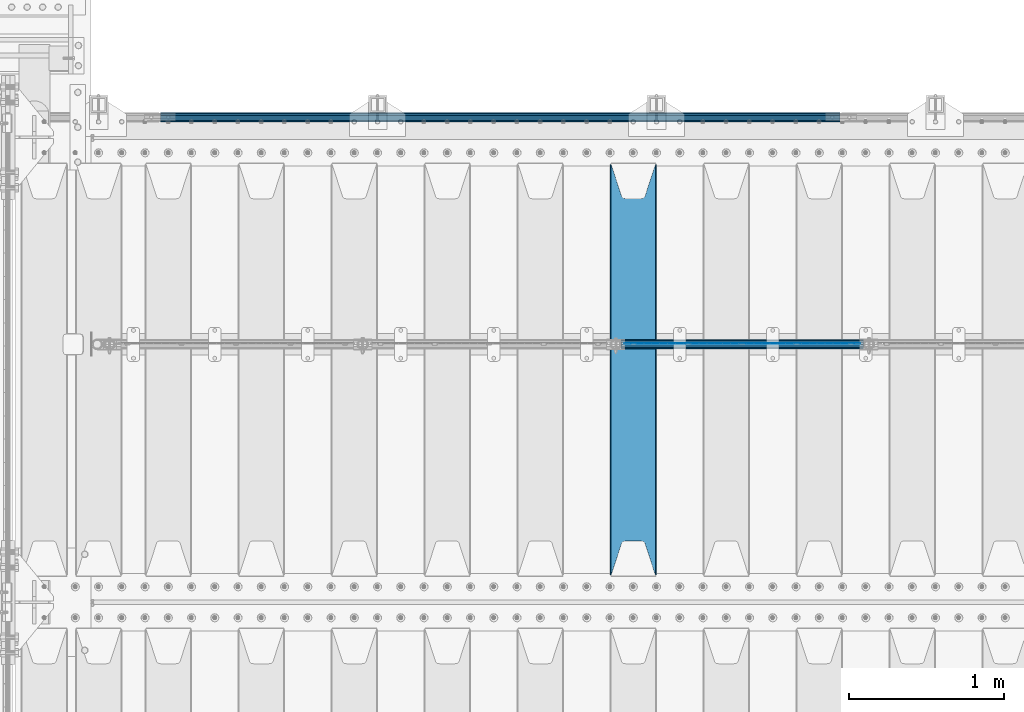
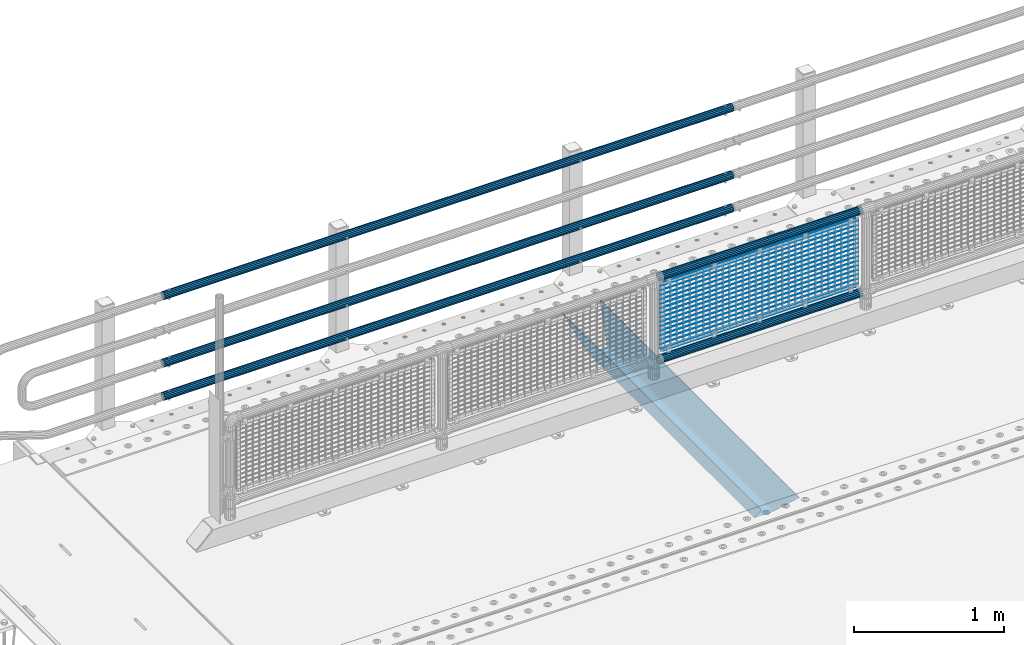
# One storey, part 130 of 270: 23 beams.
"""IFC2X3 building model written with IfcOpenShell, lengths in millimetres."""

from ifc_helpers import new_model, si_unit, frame, origin_with_axes, place, context, subcontext, project, spatial, faceted_brep, material, type_object, element, save


model = new_model("IFC2X3")

# Units and contexts
model_context = context("Model", 3, precision=1e-05, world=origin_with_axes())
body_context = subcontext(model_context, "Body", "Model", "MODEL_VIEW")
ifc_project = project(units=[si_unit("LENGTHUNIT", "METRE", prefix="MILLI"), si_unit("AREAUNIT", "SQUARE_METRE"), si_unit("VOLUMEUNIT", "CUBIC_METRE"), si_unit("MASSUNIT", "GRAM", prefix="KILO"), si_unit("TIMEUNIT", "SECOND"), si_unit("PLANEANGLEUNIT", "RADIAN"), si_unit("SOLIDANGLEUNIT", "STERADIAN"), si_unit("THERMODYNAMICTEMPERATUREUNIT", "DEGREE_CELSIUS"), si_unit("LUMINOUSINTENSITYUNIT", "LUMEN")], contexts=[model_context])

# Site, building, storey
site_placement = place(None, origin_with_axes())
site = spatial("IfcSite", under=ifc_project, at=site_placement, CompositionType="ELEMENT")
building_placement = place(site_placement, origin_with_axes())
building = spatial("IfcBuilding", under=site, at=building_placement, Name="Standard", CompositionType="ELEMENT")
storey_placement = place(building_placement, origin_with_axes())
storey = spatial("IfcBuildingStorey", under=building, at=storey_placement, Name="Undefined", CompositionType="ELEMENT", Elevation=0.0)

# Beams
ifc_material_1 = material()
beam_type_1 = type_object("IfcBeamType", PredefinedType="NOTDEFINED")
beam_1_placement = place(storey_placement, frame((5333.99999999987, -14870.1499999999, 149.849999999726), z_axis=(0.0, 0.0, -1.0), x_axis=(-1.0, 0.0, 0.0)))
element("IfcBeam", 1, at=beam_1_placement, inside=storey, type_object=beam_type_1, material=ifc_material_1, context=body_context, shape_type="Brep", body=[
    faceted_brep([(0.0, -26.5499999999993, 0.0), (0.0, -24.5290015881747, 10.1602451292931), (4384.00249699992, -24.5290015881747, 10.1602451292931), (4384.00249699992, -26.5499999999993, 0.0), (0.0, -18.7736850405036, 18.7736850405028), (4384.00249699992, -18.7736850405036, 18.7736850405028), (0.0, -10.1602451292929, 24.5290015881747), (4384.00249699992, -10.1602451292929, 24.5290015881747), (0.0, 0.0, 26.55), (4384.00249699992, 0.0, 26.55), (0.0, 10.1602451292929, 24.5290015881747), (4384.00249699992, 10.1602451292929, 24.5290015881747), (0.0, 18.7736850405036, 18.7736850405028), (4384.00249699992, 18.7736850405036, 18.7736850405028), (0.0, 24.5290015881747, 10.1602451292931), (4384.00249699992, 24.5290015881747, 10.1602451292931), (0.0, 26.5499999999993, 0.0), (4384.00249699992, 26.5499999999993, 0.0), (0.0, 24.5290015881747, -10.1602451292931), (4384.00249699992, 24.5290015881747, -10.1602451292931), (0.0, 18.7736850405036, -18.7736850405028), (4384.00249699992, 18.7736850405036, -18.7736850405028), (0.0, 10.1602451292929, -24.5290015881747), (4384.00249699992, 10.1602451292929, -24.5290015881747), (0.0, 0.0, -26.55), (4384.00249699992, 0.0, -26.55), (0.0, -10.1602451292929, -24.5290015881747), (4384.00249699992, -10.1602451292929, -24.5290015881747), (0.0, -18.7736850405036, -18.7736850405028), (4384.00249699992, -18.7736850405036, -18.7736850405028), (0.0, -24.5290015881747, -10.1602451292931), (4384.00249699992, -24.5290015881747, -10.1602451292931), (0.0, -30.1499999999996, 0.0), (0.0, -27.8549679052157, -11.5379054858058), (4384.00249699992, -27.8549679052157, -11.5379054858075), (4384.00249699992, -30.1499999999996, 0.0), (0.0, -21.3192694527752, -21.3192694527752), (4384.00249699992, -21.3192694527752, -21.3192694527744), (0.0, -11.5379054858076, -27.8549679052157), (4384.00249699992, -11.5379054858076, -27.8549679052153), (0.0, 0.0, -30.1500000000015), (4384.00249699992, 0.0, -30.15), (0.0, 11.5379054858076, -27.8549679052157), (4384.00249699992, 11.5379054858076, -27.8549679052153), (0.0, 21.3192694527752, -21.3192694527752), (4384.00249699992, 21.3192694527752, -21.3192694527744), (0.0, 27.8549679052157, -11.5379054858058), (4384.00249699992, 27.8549679052157, -11.5379054858074), (0.0, 30.1499999999996, 0.0), (4384.00249699992, 30.1499999999996, 0.0), (0.0, 27.8549679052157, 11.5379054858058), (4384.00249699992, 27.8549679052157, 11.5379054858075), (0.0, 21.3192694527752, 21.3192694527752), (4384.00249699992, 21.3192694527752, 21.3192694527744), (0.0, 11.5379054858076, 27.8549679052157), (4384.00249699992, 11.5379054858076, 27.8549679052153), (0.0, 0.0, 30.1500000000015), (4384.00249699992, 0.0, 30.15), (0.0, -11.5379054858076, 27.8549679052157), (4384.00249699992, -11.5379054858076, 27.8549679052153), (0.0, -21.3192694527752, 21.3192694527752), (4384.00249699992, -21.3192694527752, 21.3192694527744), (0.0, -27.8549679052157, 11.5379054858058), (4384.00249699992, -27.8549679052157, 11.5379054858075)], [[[0, 1, 2, 3]], [[1, 4, 5, 2]], [[4, 6, 7, 5]], [[6, 8, 9, 7]], [[8, 10, 11, 9]], [[10, 12, 13, 11]], [[12, 14, 15, 13]], [[14, 16, 17, 15]], [[16, 18, 19, 17]], [[18, 20, 21, 19]], [[20, 22, 23, 21]], [[22, 24, 25, 23]], [[24, 26, 27, 25]], [[26, 28, 29, 27]], [[28, 30, 31, 29]], [[30, 0, 3, 31]], [[32, 33, 34, 35]], [[33, 36, 37, 34]], [[36, 38, 39, 37]], [[38, 40, 41, 39]], [[40, 42, 43, 41]], [[42, 44, 45, 43]], [[44, 46, 47, 45]], [[46, 48, 49, 47]], [[48, 50, 51, 49]], [[50, 52, 53, 51]], [[52, 54, 55, 53]], [[54, 56, 57, 55]], [[56, 58, 59, 57]], [[58, 60, 61, 59]], [[60, 62, 63, 61]], [[62, 32, 35, 63]], [[37, 39, 41, 43, 45, 47, 49, 51, 53, 55, 57, 59, 61, 63, 35, 34], [5, 7, 9, 11, 13, 15, 17, 19, 21, 23, 25, 27, 29, 31, 3, 2]], [[62, 60, 58, 56, 54, 52, 50, 48, 46, 44, 42, 40, 38, 36, 33, 32], [30, 28, 26, 24, 22, 20, 18, 16, 14, 12, 10, 8, 6, 4, 1, 0]]]),
])
beam_2_placement = place(storey_placement, frame((5333.99999999987, -14870.1499999999, 420.149999999729), z_axis=(0.0, 0.0, -1.0), x_axis=(-1.0, 0.0, 0.0)))
element("IfcBeam", 2, at=beam_2_placement, inside=storey, type_object=beam_type_1, material=ifc_material_1, context=body_context, shape_type="Brep", body=[
    faceted_brep([(0.0, -26.5499999999993, 0.0), (0.0, -24.5290015881747, 10.1602451292931), (4384.00249699992, -24.5290015881747, 10.1602451292931), (4384.00249699992, -26.5499999999993, 0.0), (0.0, -18.7736850405036, 18.7736850405028), (4384.00249699992, -18.7736850405036, 18.7736850405028), (0.0, -10.1602451292929, 24.5290015881747), (4384.00249699992, -10.1602451292929, 24.5290015881747), (0.0, 0.0, 26.55), (4384.00249699992, 0.0, 26.55), (0.0, 10.1602451292929, 24.5290015881747), (4384.00249699992, 10.1602451292929, 24.5290015881747), (0.0, 18.7736850405036, 18.7736850405028), (4384.00249699992, 18.7736850405036, 18.7736850405028), (0.0, 24.5290015881747, 10.1602451292931), (4384.00249699992, 24.5290015881747, 10.1602451292931), (0.0, 26.5499999999993, 0.0), (4384.00249699992, 26.5499999999993, 0.0), (0.0, 24.5290015881747, -10.1602451292931), (4384.00249699992, 24.5290015881747, -10.1602451292931), (0.0, 18.7736850405036, -18.7736850405028), (4384.00249699992, 18.7736850405036, -18.7736850405028), (0.0, 10.1602451292929, -24.5290015881747), (4384.00249699992, 10.1602451292929, -24.5290015881747), (0.0, 0.0, -26.55), (4384.00249699992, 0.0, -26.55), (0.0, -10.1602451292929, -24.5290015881747), (4384.00249699992, -10.1602451292929, -24.5290015881747), (0.0, -18.7736850405036, -18.7736850405028), (4384.00249699992, -18.7736850405036, -18.7736850405028), (0.0, -24.5290015881747, -10.1602451292931), (4384.00249699992, -24.5290015881747, -10.1602451292931), (0.0, -30.1499999999996, 0.0), (0.0, -27.8549679052157, -11.5379054858058), (4384.00249699992, -27.8549679052157, -11.5379054858075), (4384.00249699992, -30.1499999999996, 0.0), (0.0, -21.3192694527752, -21.3192694527752), (4384.00249699992, -21.3192694527752, -21.3192694527744), (0.0, -11.5379054858076, -27.8549679052157), (4384.00249699992, -11.5379054858076, -27.8549679052153), (0.0, 0.0, -30.1500000000015), (4384.00249699992, 0.0, -30.15), (0.0, 11.5379054858076, -27.8549679052157), (4384.00249699992, 11.5379054858076, -27.8549679052153), (0.0, 21.3192694527752, -21.3192694527752), (4384.00249699992, 21.3192694527752, -21.3192694527744), (0.0, 27.8549679052157, -11.5379054858058), (4384.00249699992, 27.8549679052157, -11.5379054858074), (0.0, 30.1499999999996, 0.0), (4384.00249699992, 30.1499999999996, 0.0), (0.0, 27.8549679052157, 11.5379054858058), (4384.00249699992, 27.8549679052157, 11.5379054858075), (0.0, 21.3192694527752, 21.3192694527752), (4384.00249699992, 21.3192694527752, 21.3192694527744), (0.0, 11.5379054858076, 27.8549679052157), (4384.00249699992, 11.5379054858076, 27.8549679052153), (0.0, 0.0, 30.1500000000015), (4384.00249699992, 0.0, 30.15), (0.0, -11.5379054858076, 27.8549679052157), (4384.00249699992, -11.5379054858076, 27.8549679052153), (0.0, -21.3192694527752, 21.3192694527752), (4384.00249699992, -21.3192694527752, 21.3192694527744), (0.0, -27.8549679052157, 11.5379054858058), (4384.00249699992, -27.8549679052157, 11.5379054858075)], [[[0, 1, 2, 3]], [[1, 4, 5, 2]], [[4, 6, 7, 5]], [[6, 8, 9, 7]], [[8, 10, 11, 9]], [[10, 12, 13, 11]], [[12, 14, 15, 13]], [[14, 16, 17, 15]], [[16, 18, 19, 17]], [[18, 20, 21, 19]], [[20, 22, 23, 21]], [[22, 24, 25, 23]], [[24, 26, 27, 25]], [[26, 28, 29, 27]], [[28, 30, 31, 29]], [[30, 0, 3, 31]], [[32, 33, 34, 35]], [[33, 36, 37, 34]], [[36, 38, 39, 37]], [[38, 40, 41, 39]], [[40, 42, 43, 41]], [[42, 44, 45, 43]], [[44, 46, 47, 45]], [[46, 48, 49, 47]], [[48, 50, 51, 49]], [[50, 52, 53, 51]], [[52, 54, 55, 53]], [[54, 56, 57, 55]], [[56, 58, 59, 57]], [[58, 60, 61, 59]], [[60, 62, 63, 61]], [[62, 32, 35, 63]], [[37, 39, 41, 43, 45, 47, 49, 51, 53, 55, 57, 59, 61, 63, 35, 34], [5, 7, 9, 11, 13, 15, 17, 19, 21, 23, 25, 27, 29, 31, 3, 2]], [[62, 60, 58, 56, 54, 52, 50, 48, 46, 44, 42, 40, 38, 36, 33, 32], [30, 28, 26, 24, 22, 20, 18, 16, 14, 12, 10, 8, 6, 4, 1, 0]]]),
])
beam_3_placement = place(storey_placement, frame((5333.99999999987, -14870.1499999999, 969.849999999726), z_axis=(0.0, 0.0, -1.0), x_axis=(-1.0, 0.0, 0.0)))
element("IfcBeam", 3, at=beam_3_placement, inside=storey, type_object=beam_type_1, material=ifc_material_1, context=body_context, shape_type="Brep", body=[
    faceted_brep([(0.0, -26.5499999999993, 0.0), (0.0, -24.5290015881747, 10.1602451292931), (4384.00249699992, -24.5290015881747, 10.1602451292931), (4384.00249699992, -26.5499999999993, 0.0), (0.0, -18.7736850405036, 18.7736850405028), (4384.00249699992, -18.7736850405036, 18.7736850405028), (0.0, -10.1602451292929, 24.5290015881747), (4384.00249699992, -10.1602451292929, 24.5290015881747), (0.0, 0.0, 26.55), (4384.00249699992, 0.0, 26.55), (0.0, 10.1602451292929, 24.5290015881747), (4384.00249699992, 10.1602451292929, 24.5290015881747), (0.0, 18.7736850405036, 18.7736850405028), (4384.00249699992, 18.7736850405036, 18.7736850405028), (0.0, 24.5290015881747, 10.1602451292931), (4384.00249699992, 24.5290015881747, 10.1602451292931), (0.0, 26.5499999999993, 0.0), (4384.00249699992, 26.5499999999993, 0.0), (0.0, 24.5290015881747, -10.1602451292931), (4384.00249699992, 24.5290015881747, -10.1602451292931), (0.0, 18.7736850405036, -18.7736850405028), (4384.00249699992, 18.7736850405036, -18.7736850405028), (0.0, 10.1602451292929, -24.5290015881747), (4384.00249699992, 10.1602451292929, -24.5290015881747), (0.0, 0.0, -26.55), (4384.00249699992, 0.0, -26.55), (0.0, -10.1602451292929, -24.5290015881747), (4384.00249699992, -10.1602451292929, -24.5290015881747), (0.0, -18.7736850405036, -18.7736850405028), (4384.00249699992, -18.7736850405036, -18.7736850405028), (0.0, -24.5290015881747, -10.1602451292931), (4384.00249699992, -24.5290015881747, -10.1602451292931), (0.0, -30.1499999999996, 0.0), (0.0, -27.8549679052157, -11.5379054858058), (4384.00249699992, -27.8549679052157, -11.5379054858075), (4384.00249699992, -30.1499999999996, 0.0), (0.0, -21.3192694527752, -21.3192694527752), (4384.00249699992, -21.3192694527752, -21.3192694527744), (0.0, -11.5379054858076, -27.8549679052157), (4384.00249699992, -11.5379054858076, -27.8549679052153), (0.0, 0.0, -30.1500000000015), (4384.00249699992, 0.0, -30.15), (0.0, 11.5379054858076, -27.8549679052157), (4384.00249699992, 11.5379054858076, -27.8549679052153), (0.0, 21.3192694527752, -21.3192694527752), (4384.00249699992, 21.3192694527752, -21.3192694527744), (0.0, 27.8549679052157, -11.5379054858058), (4384.00249699992, 27.8549679052157, -11.5379054858074), (0.0, 30.1499999999996, 0.0), (4384.00249699992, 30.1499999999996, 0.0), (0.0, 27.8549679052157, 11.5379054858058), (4384.00249699992, 27.8549679052157, 11.5379054858075), (0.0, 21.3192694527752, 21.3192694527752), (4384.00249699992, 21.3192694527752, 21.3192694527744), (0.0, 11.5379054858076, 27.8549679052157), (4384.00249699992, 11.5379054858076, 27.8549679052153), (0.0, 0.0, 30.1500000000015), (4384.00249699992, 0.0, 30.15), (0.0, -11.5379054858076, 27.8549679052157), (4384.00249699992, -11.5379054858076, 27.8549679052153), (0.0, -21.3192694527752, 21.3192694527752), (4384.00249699992, -21.3192694527752, 21.3192694527744), (0.0, -27.8549679052157, 11.5379054858058), (4384.00249699992, -27.8549679052157, 11.5379054858075)], [[[0, 1, 2, 3]], [[1, 4, 5, 2]], [[4, 6, 7, 5]], [[6, 8, 9, 7]], [[8, 10, 11, 9]], [[10, 12, 13, 11]], [[12, 14, 15, 13]], [[14, 16, 17, 15]], [[16, 18, 19, 17]], [[18, 20, 21, 19]], [[20, 22, 23, 21]], [[22, 24, 25, 23]], [[24, 26, 27, 25]], [[26, 28, 29, 27]], [[28, 30, 31, 29]], [[30, 0, 3, 31]], [[32, 33, 34, 35]], [[33, 36, 37, 34]], [[36, 38, 39, 37]], [[38, 40, 41, 39]], [[40, 42, 43, 41]], [[42, 44, 45, 43]], [[44, 46, 47, 45]], [[46, 48, 49, 47]], [[48, 50, 51, 49]], [[50, 52, 53, 51]], [[52, 54, 55, 53]], [[54, 56, 57, 55]], [[56, 58, 59, 57]], [[58, 60, 61, 59]], [[60, 62, 63, 61]], [[62, 32, 35, 63]], [[37, 39, 41, 43, 45, 47, 49, 51, 53, 55, 57, 59, 61, 63, 35, 34], [5, 7, 9, 11, 13, 15, 17, 19, 21, 23, 25, 27, 29, 31, 3, 2]], [[62, 60, 58, 56, 54, 52, 50, 48, 46, 44, 42, 40, 38, 36, 33, 32], [30, 28, 26, 24, 22, 20, 18, 16, 14, 12, 10, 8, 6, 4, 1, 0]]]),
])
ifc_material_2 = material(Name="STEEL/S355N")
beam_type_2 = type_object("IfcBeamType", PredefinedType="NOTDEFINED")
beam_4_placement = place(storey_placement, frame((4000.0, -17825.0, -115.0), z_axis=(0.0, 0.0, 1.0), x_axis=(0.0, 1.0, 0.0)))
element("IfcBeam", 4, at=beam_4_placement, inside=storey, type_object=beam_type_2, material=ifc_material_2, context=body_context, shape_type="Brep", body=[
    faceted_brep([(0.0, 150.0, 115.0), (0.0, 143.689999999999, 115.0), (2650.00000000297, 143.689999999999, 115.0), (2650.00000000297, 150.0, 115.0), (2650.00000000297, 142.059565218398, 110.000000003096), (2650.00000000297, 148.3695652184, 110.000000003096), (2441.90079219209, -80.1103600731112, -98.0992078077845), (2437.7588105432, -77.5672621345584, -102.241189456673), (2434.06523489747, -74.4080125315522, -105.934765102404), (2430.9108609509, -70.710272125576, -109.089139048974), (2428.37322971128, -66.5649389910068, -111.626770288588), (2426.51472138055, -62.0739139532889, -113.485278619323), (2425.38102192092, -57.3475956567672, -114.618978078955), (2424.99999999987, -52.5021667386536, -115.0), (2424.99999999987, 52.5021667386536, -115.0), (2425.38102192092, 57.3475956567672, -114.618978078955), (2426.51472138055, 62.0739139532889, -113.485278619323), (2428.37322971128, 66.5649389910068, -111.626770288588), (2430.9108609509, 70.710272125576, -109.089139048974), (2434.06523489747, 74.4080125315522, -105.934765102404), (2437.7588105432, 77.5672621345584, -102.241189456673), (2441.90079219209, 80.1103600731112, -98.0992078077846), (2446.38936140511, 81.9747917625791, -93.6106385947584), (2448.2494850041, 76.2713538057251, -91.7505149957729), (2444.62967112263, 74.76777986261, -95.3703288772456), (2441.28936334126, 72.7168944282894, -98.710636658607), (2438.31067330439, 70.1691124903846, -101.689326695487), (2435.76682334747, 67.1870637758839, -104.233176652398), (2433.72034654133, 63.8440531834895, -106.279653458539), (2432.22154950042, 60.222258798236, -107.778450499454), (2431.30727574265, 56.4107117849089, -108.692724257221), (2430.99999999987, 52.5031078186876, -109.0), (2430.99999999987, -52.5031078186876, -109.0), (2431.30727574265, -56.4107117849089, -108.692724257221), (2432.22154950042, -60.222258798236, -107.778450499454), (2433.72034654133, -63.8440531834895, -106.279653458539), (2435.76682334747, -67.1870637758839, -104.233176652398), (2438.31067330438, -70.1691124903846, -101.689326695487), (2441.28936334126, -72.7168944282894, -98.7106366586071), (2444.62967112263, -74.76777986261, -95.3703288772457), (2448.2494850041, -76.2713538057251, -91.7505149957729), (2650.00000000297, -142.059565218398, 110.000000003096), (2650.00000000297, -148.3695652184, 110.000000003096), (2446.38936140511, -81.9747917625791, -93.6106385947584), (2650.00000000297, -143.689999999999, 115.0), (2650.00000000297, -150.0, 115.0), (0.0, -143.689999999999, 115.0), (0.0, -150.0, 115.0), (0.0, -148.369565218261, 110.000000002672), (203.610638597431, -81.9747917625791, -93.6106385947584), (208.099207810457, -80.1103600731112, -98.0992078077845), (212.241189459342, -77.5672621345584, -102.241189456673), (215.934765105078, -74.4080125315522, -105.934765102404), (219.089139051644, -70.710272125576, -109.089139048974), (221.626770291259, -66.5649389910068, -111.626770288588), (223.485278621993, -62.0739139532889, -113.485278619323), (224.618978081628, -57.3475956567672, -114.618978078955), (225.00000000267, -52.5021667386536, -115.0), (225.00000000267, 52.5021667386536, -115.0), (224.618978081628, 57.3475956567672, -114.618978078955), (223.485278621993, 62.0739139532889, -113.485278619323), (221.626770291259, 66.5649389910068, -111.626770288588), (219.089139051644, 70.710272125576, -109.089139048974), (215.934765105078, 74.4080125315522, -105.934765102404), (212.241189459342, 77.5672621345584, -102.241189456673), (208.099207810457, 80.1103600731112, -98.0992078077846), (203.610638597431, 81.9747917625791, -93.6106385947584), (0.0, 148.369565218261, 110.000000002672), (0.0, 142.05956521826, 110.000000002672), (201.750514998446, 76.2713538057251, -91.7505149957729), (205.370328879915, 74.76777986261, -95.3703288772456), (208.710636661279, 72.7168944282894, -98.710636658607), (211.689326698157, 70.1691124903846, -101.689326695487), (214.233176655071, 67.1870637758839, -104.233176652398), (216.27965346121, 63.8440531834895, -106.279653458539), (217.778450502126, 60.222258798236, -107.778450499454), (218.692724259894, 56.4107117849089, -108.692724257221), (219.00000000267, 52.5031078186876, -109.0), (219.00000000267, -52.5031078186876, -109.0), (218.692724259894, -56.4107117849089, -108.692724257221), (217.778450502123, -60.222258798236, -107.778450499454), (216.27965346121, -63.8440531834895, -106.279653458539), (214.233176655071, -67.1870637758839, -104.233176652398), (211.689326698157, -70.1691124903846, -101.689326695487), (208.710636661279, -72.7168944282894, -98.7106366586071), (205.370328879915, -74.76777986261, -95.3703288772457), (201.750514998446, -76.2713538057251, -91.7505149957729), (0.0, -142.05956521826, 110.000000002672)], [[[0, 1, 2, 3]], [[3, 2, 4, 5]], [[6, 7, 8, 9, 10, 11, 12, 13, 14, 15, 16, 17, 18, 19, 20, 21, 22, 5, 4, 23, 24, 25, 26, 27, 28, 29, 30, 31, 32, 33, 34, 35, 36, 37, 38, 39, 40, 41, 42, 43]], [[44, 45, 42, 41]], [[46, 47, 45, 44]], [[43, 42, 45, 47, 48, 49]], [[6, 43, 49, 50]], [[7, 6, 50, 51]], [[8, 7, 51, 52]], [[9, 8, 52, 53]], [[10, 9, 53, 54]], [[11, 10, 54, 55]], [[12, 11, 55, 56]], [[13, 12, 56, 57]], [[14, 13, 57, 58]], [[15, 14, 58, 59]], [[16, 15, 59, 60]], [[17, 16, 60, 61]], [[18, 17, 61, 62]], [[19, 18, 62, 63]], [[20, 19, 63, 64]], [[21, 20, 64, 65]], [[22, 21, 65, 66]], [[0, 3, 5, 22, 66, 67]], [[1, 0, 67, 68]], [[23, 4, 2, 1, 68, 69]], [[24, 23, 69, 70]], [[25, 24, 70, 71]], [[26, 25, 71, 72]], [[27, 26, 72, 73]], [[28, 27, 73, 74]], [[29, 28, 74, 75]], [[30, 29, 75, 76]], [[31, 30, 76, 77]], [[32, 31, 77, 78]], [[33, 32, 78, 79]], [[34, 33, 79, 80]], [[35, 34, 80, 81]], [[36, 35, 81, 82]], [[37, 36, 82, 83]], [[38, 37, 83, 84]], [[39, 38, 84, 85]], [[40, 39, 85, 86]], [[46, 44, 41, 40, 86, 87]], [[47, 46, 87, 48]], [[86, 85, 84, 83, 82, 81, 80, 79, 78, 77, 76, 75, 74, 73, 72, 71, 70, 69, 68, 67, 66, 65, 64, 63, 62, 61, 60, 59, 58, 57, 56, 55, 54, 53, 52, 51, 50, 49, 48, 87]]]),
])
ifc_material_3 = material(Name="Misc_Undefined")
beam_type_3 = type_object("IfcBeamType", Name="D3", PredefinedType="NOTDEFINED")
for number, where, z_axis, x_axis in (
    (5, (3942.0, -16329.5, 851.596999999999), (0.0, 0.0, 1.0), (1.0, 0.0, 0.0)),
    (6, (3942.0, -16329.5, 669.452), (0.0, 0.0, 1.0), (1.0, 0.0, 0.0)),
    (7, (3942.0, -16329.5, 523.736), (0.0, 0.0, 1.0), (1.0, 0.0, 0.0)),
    (8, (3942.0, -16329.5, 487.307), (0.0, 0.0, 1.0), (1.0, 0.0, 0.0)),
    (9, (3942.0, -16329.5, 705.881), (0.0, 0.0, 1.0), (1.0, 0.0, 0.0)),
    (10, (3942.0, -16329.5, 596.594), (0.0, 0.0, 1.0), (1.0, 0.0, 0.0)),
    (11, (3942.0, -16329.5, 450.878), (0.0, 0.0, 1.0), (1.0, 0.0, 0.0)),
    (12, (3942.0, -16329.5, 815.167999999999), (0.0, 0.0, 1.0), (1.0, 0.0, 0.0)),
    (13, (3942.0, -16329.5, 888.025999999999), (0.0, 0.0, 1.0), (1.0, 0.0, 0.0)),
    (14, (3942.0, -16329.5, 778.738999999999), (0.0, 0.0, 1.0), (1.0, 0.0, 0.0)),
    (15, (3942.0, -16329.5, 742.309999999999), (0.0, 0.0, 1.0), (1.0, 0.0, 0.0)),
    (16, (3942.0, -16329.5, 633.023), (0.0, 0.0, 1.0), (1.0, 0.0, 0.0)),
    (17, (3942.0, -16329.5, 560.165), (0.0, 0.0, 1.0), (1.0, 0.0, 0.0)),
    (18, (3942.0, -16329.5, 414.449), (0.0, 0.0, 1.0), (1.0, 0.0, 0.0)),
):
    element("IfcBeam", number, at=place(storey_placement, frame(where, z_axis=z_axis, x_axis=x_axis)), inside=storey, type_object=beam_type_3, material=ifc_material_3, ObjectType="D3", context=body_context, shape_type="Brep", body=[
        faceted_brep([(0.0, -1.5, 0.0), (0.0, -0.75, -1.29903810567669), (1523.0, -0.75, -1.29903810567669), (1523.0, -1.5, 0.0), (0.0, 0.75, -1.29903810567669), (1523.0, 0.75, -1.29903810567669), (0.0, 1.5, 0.0), (1523.0, 1.5, 0.0), (0.0, 0.75, 1.29903810567669), (1523.0, 0.75, 1.29903810567669), (0.0, -0.75, 1.29903810567669), (1523.0, -0.75, 1.29903810567669)], [[[0, 1, 2, 3]], [[1, 4, 5, 2]], [[4, 6, 7, 5]], [[6, 8, 9, 7]], [[8, 10, 11, 9]], [[10, 0, 3, 11]], [[5, 7, 9, 11, 3, 2]], [[10, 8, 6, 4, 1, 0]]]),
    ])
beam_5_placement = place(storey_placement, frame((3967.0, -16329.5, 353.02), z_axis=(0.0, 0.0, 1.0), x_axis=(1.0, 0.0, 0.0)))
element("IfcBeam", 19, at=beam_5_placement, inside=storey, type_object=beam_type_3, material=ifc_material_3, ObjectType="D3", context=body_context, shape_type="Brep", body=[
    faceted_brep([(0.0, -1.5, 0.0), (0.0, -0.75, -1.29903810567669), (1473.0, -0.75, -1.29903810567669), (1473.0, -1.5, 0.0), (0.0, 0.75, -1.29903810567669), (1473.0, 0.75, -1.29903810567663), (0.0, 1.5, 0.0), (1473.0, 1.5, 0.0), (0.0, 0.75, 1.29903810567669), (1473.0, 0.75, 1.29903810567669), (0.0, -0.75, 1.29903810567669), (1473.0, -0.75, 1.29903810567669)], [[[0, 1, 2, 3]], [[1, 4, 5, 2]], [[4, 6, 7, 5]], [[6, 8, 9, 7]], [[8, 10, 11, 9]], [[10, 0, 3, 11]], [[5, 7, 9, 11, 3, 2]], [[10, 8, 6, 4, 1, 0]]]),
])
beam_6_placement = place(storey_placement, frame((3942.0, -16329.5, 378.02), z_axis=(0.0, 0.0, 1.0), x_axis=(1.0, 0.0, 0.0)))
element("IfcBeam", 20, at=beam_6_placement, inside=storey, type_object=beam_type_3, material=ifc_material_3, ObjectType="D3", context=body_context, shape_type="Brep", body=[
    faceted_brep([(0.0, -1.5, 0.0), (0.0, -0.75, -1.29903810567669), (1523.0, -0.75, -1.29903810567669), (1523.0, -1.5, 0.0), (0.0, 0.75, -1.29903810567669), (1523.0, 0.75, -1.29903810567669), (0.0, 1.5, 0.0), (1523.0, 1.5, 0.0), (0.0, 0.75, 1.29903810567669), (1523.0, 0.75, 1.29903810567669), (0.0, -0.75, 1.29903810567669), (1523.0, -0.75, 1.29903810567669)], [[[0, 1, 2, 3]], [[1, 4, 5, 2]], [[4, 6, 7, 5]], [[6, 8, 9, 7]], [[8, 10, 11, 9]], [[10, 0, 3, 11]], [[5, 7, 9, 11, 3, 2]], [[10, 8, 6, 4, 1, 0]]]),
])
beam_7_placement = place(storey_placement, frame((3967.0, -16329.5, 913.02), z_axis=(0.0, 0.0, 1.0), x_axis=(1.0, 0.0, 0.0)))
element("IfcBeam", 21, at=beam_7_placement, inside=storey, type_object=beam_type_3, material=ifc_material_3, ObjectType="D3", context=body_context, shape_type="Brep", body=[
    faceted_brep([(0.0, -1.5, 0.0), (0.0, -0.75, -1.29903810567669), (1473.0, -0.75, -1.29903810567669), (1473.0, -1.5, 0.0), (0.0, 0.75, -1.29903810567669), (1473.0, 0.75, -1.29903810567663), (0.0, 1.5, 0.0), (1473.0, 1.5, 0.0), (0.0, 0.75, 1.29903810567669), (1473.0, 0.75, 1.29903810567669), (0.0, -0.75, 1.29903810567669), (1473.0, -0.75, 1.29903810567669)], [[[0, 1, 2, 3]], [[1, 4, 5, 2]], [[4, 6, 7, 5]], [[6, 8, 9, 7]], [[8, 10, 11, 9]], [[10, 0, 3, 11]], [[5, 7, 9, 11, 3, 2]], [[10, 8, 6, 4, 1, 0]]]),
])
beam_type_4 = type_object("IfcBeamType", PredefinedType="NOTDEFINED")
beam_8_placement = place(storey_placement, frame((3921.85, -16335.5, 969.849999999999), z_axis=(0.0, 0.0, 1.0), x_axis=(1.0, 0.0, 0.0)))
element("IfcBeam", 22, at=beam_8_placement, inside=storey, type_object=beam_type_4, material=ifc_material_1, context=body_context, shape_type="Brep", body=[
    faceted_brep([(0.0, -25.3500000000004, 0.0), (0.0, -23.4203461491616, 9.70102501045403), (1563.0, -23.4203461491616, 9.70102501045506), (1563.0, -25.3500000000004, 0.0), (0.0, -17.9251569030785, 17.9251569030785), (1563.0, -17.9251569030785, 17.925156903079), (0.0, -9.70102501045585, 23.4203461491597), (1563.0, -9.70102501045585, 23.4203461491611), (0.0, 0.0, 25.3499999999985), (1563.0, 0.0, 25.35), (0.0, 9.70102501045585, 23.4203461491597), (1563.0, 9.70102501045585, 23.4203461491611), (0.0, 17.9251569030785, 17.9251569030785), (1563.0, 17.9251569030785, 17.925156903079), (0.0, 23.4203461491616, 9.70102501045403), (1563.0, 23.4203461491616, 9.70102501045506), (0.0, 25.3500000000004, 0.0), (1563.0, 25.3500000000004, 0.0), (0.0, 23.4203461491616, -9.70102501045403), (1563.0, 23.4203461491616, -9.70102501045506), (0.0, 17.9251569030785, -17.9251569030785), (1563.0, 17.9251569030785, -17.925156903079), (0.0, 9.70102501045585, -23.4203461491597), (1563.0, 9.70102501045585, -23.4203461491611), (0.0, 0.0, -25.3499999999985), (1563.0, 0.0, -25.35), (0.0, -9.70102501045585, -23.4203461491597), (1563.0, -9.70102501045585, -23.4203461491611), (0.0, -17.9251569030785, -17.9251569030785), (1563.0, -17.9251569030785, -17.925156903079), (0.0, -23.4203461491616, -9.70102501045403), (1563.0, -23.4203461491616, -9.70102501045506), (0.0, -30.1499999999996, 0.0), (0.0, -27.8549679052157, -11.5379054858058), (1563.0, -27.8549679052157, -11.5379054858075), (1563.0, -30.1499999999996, 0.0), (0.0, -21.3192694527752, -21.3192694527752), (1563.0, -21.3192694527752, -21.3192694527744), (0.0, -11.5379054858076, -27.8549679052157), (1563.0, -11.5379054858076, -27.8549679052153), (0.0, 0.0, -30.1500000000015), (1563.0, 0.0, -30.15), (0.0, 11.5379054858076, -27.8549679052157), (1563.0, 11.5379054858076, -27.8549679052153), (0.0, 21.3192694527752, -21.3192694527752), (1563.0, 21.3192694527752, -21.3192694527744), (0.0, 27.8549679052157, -11.5379054858058), (1563.0, 27.8549679052157, -11.5379054858074), (0.0, 30.1499999999996, 0.0), (1563.0, 30.1499999999996, 0.0), (0.0, 27.8549679052157, 11.5379054858058), (1563.0, 27.8549679052157, 11.5379054858074), (0.0, 21.3192694527752, 21.3192694527752), (1563.0, 21.3192694527752, 21.3192694527744), (0.0, 11.5379054858076, 27.8549679052157), (1563.0, 11.5379054858076, 27.8549679052153), (0.0, 0.0, 30.1500000000015), (1563.0, 0.0, 30.15), (0.0, -11.5379054858076, 27.8549679052157), (1563.0, -11.5379054858076, 27.8549679052153), (0.0, -21.3192694527752, 21.3192694527752), (1563.0, -21.3192694527752, 21.3192694527744), (0.0, -27.8549679052157, 11.5379054858058), (1563.0, -27.8549679052157, 11.5379054858074)], [[[0, 1, 2, 3]], [[1, 4, 5, 2]], [[4, 6, 7, 5]], [[6, 8, 9, 7]], [[8, 10, 11, 9]], [[10, 12, 13, 11]], [[12, 14, 15, 13]], [[14, 16, 17, 15]], [[16, 18, 19, 17]], [[18, 20, 21, 19]], [[20, 22, 23, 21]], [[22, 24, 25, 23]], [[24, 26, 27, 25]], [[26, 28, 29, 27]], [[28, 30, 31, 29]], [[30, 0, 3, 31]], [[32, 33, 34, 35]], [[33, 36, 37, 34]], [[36, 38, 39, 37]], [[38, 40, 41, 39]], [[40, 42, 43, 41]], [[42, 44, 45, 43]], [[44, 46, 47, 45]], [[46, 48, 49, 47]], [[48, 50, 51, 49]], [[50, 52, 53, 51]], [[52, 54, 55, 53]], [[54, 56, 57, 55]], [[56, 58, 59, 57]], [[58, 60, 61, 59]], [[60, 62, 63, 61]], [[62, 32, 35, 63]], [[37, 39, 41, 43, 45, 47, 49, 51, 53, 55, 57, 59, 61, 63, 35, 34], [5, 7, 9, 11, 13, 15, 17, 19, 21, 23, 25, 27, 29, 31, 3, 2]], [[62, 60, 58, 56, 54, 52, 50, 48, 46, 44, 42, 40, 38, 36, 33, 32], [30, 28, 26, 24, 22, 20, 18, 16, 14, 12, 10, 8, 6, 4, 1, 0]]]),
])
beam_9_placement = place(storey_placement, frame((3921.85000000001, -16335.5, 298.170000000001), z_axis=(0.0, 0.0, 1.0), x_axis=(1.0, 0.0, 0.0)))
element("IfcBeam", 23, at=beam_9_placement, inside=storey, type_object=beam_type_4, material=ifc_material_1, context=body_context, shape_type="Brep", body=[
    faceted_brep([(0.0, -25.3500000000004, 0.0), (0.0, -23.4203461491616, 9.70102501045403), (1563.0, -23.4203461491616, 9.70102501045506), (1563.0, -25.3500000000004, 0.0), (0.0, -17.9251569030785, 17.9251569030785), (1563.0, -17.9251569030785, 17.925156903079), (0.0, -9.70102501045585, 23.4203461491597), (1563.0, -9.70102501045585, 23.4203461491611), (0.0, 0.0, 25.3499999999985), (1563.0, 0.0, 25.35), (0.0, 9.70102501045585, 23.4203461491597), (1563.0, 9.70102501045585, 23.4203461491611), (0.0, 17.9251569030785, 17.9251569030785), (1563.0, 17.9251569030785, 17.925156903079), (0.0, 23.4203461491616, 9.70102501045403), (1563.0, 23.4203461491616, 9.70102501045506), (0.0, 25.3500000000004, 0.0), (1563.0, 25.3500000000004, 0.0), (0.0, 23.4203461491616, -9.70102501045403), (1563.0, 23.4203461491616, -9.70102501045506), (0.0, 17.9251569030785, -17.9251569030785), (1563.0, 17.9251569030785, -17.925156903079), (0.0, 9.70102501045585, -23.4203461491597), (1563.0, 9.70102501045585, -23.4203461491611), (0.0, 0.0, -25.3499999999985), (1563.0, 0.0, -25.35), (0.0, -9.70102501045585, -23.4203461491597), (1563.0, -9.70102501045585, -23.4203461491611), (0.0, -17.9251569030785, -17.9251569030785), (1563.0, -17.9251569030785, -17.925156903079), (0.0, -23.4203461491616, -9.70102501045403), (1563.0, -23.4203461491616, -9.70102501045506), (0.0, -30.1499999999996, 0.0), (0.0, -27.8549679052157, -11.5379054858058), (1563.0, -27.8549679052157, -11.5379054858075), (1563.0, -30.1499999999996, 0.0), (0.0, -21.3192694527752, -21.3192694527752), (1563.0, -21.3192694527752, -21.3192694527744), (0.0, -11.5379054858076, -27.8549679052157), (1563.0, -11.5379054858076, -27.8549679052153), (0.0, 0.0, -30.1500000000015), (1563.0, 0.0, -30.15), (0.0, 11.5379054858076, -27.8549679052157), (1563.0, 11.5379054858076, -27.8549679052153), (0.0, 21.3192694527752, -21.3192694527752), (1563.0, 21.3192694527752, -21.3192694527744), (0.0, 27.8549679052157, -11.5379054858058), (1563.0, 27.8549679052157, -11.5379054858074), (0.0, 30.1499999999996, 0.0), (1563.0, 30.1499999999996, 0.0), (0.0, 27.8549679052157, 11.5379054858058), (1563.0, 27.8549679052157, 11.5379054858074), (0.0, 21.3192694527752, 21.3192694527752), (1563.0, 21.3192694527752, 21.3192694527744), (0.0, 11.5379054858076, 27.8549679052157), (1563.0, 11.5379054858076, 27.8549679052153), (0.0, 0.0, 30.1500000000015), (1563.0, 0.0, 30.15), (0.0, -11.5379054858076, 27.8549679052157), (1563.0, -11.5379054858076, 27.8549679052153), (0.0, -21.3192694527752, 21.3192694527752), (1563.0, -21.3192694527752, 21.3192694527744), (0.0, -27.8549679052157, 11.5379054858058), (1563.0, -27.8549679052157, 11.5379054858074)], [[[0, 1, 2, 3]], [[1, 4, 5, 2]], [[4, 6, 7, 5]], [[6, 8, 9, 7]], [[8, 10, 11, 9]], [[10, 12, 13, 11]], [[12, 14, 15, 13]], [[14, 16, 17, 15]], [[16, 18, 19, 17]], [[18, 20, 21, 19]], [[20, 22, 23, 21]], [[22, 24, 25, 23]], [[24, 26, 27, 25]], [[26, 28, 29, 27]], [[28, 30, 31, 29]], [[30, 0, 3, 31]], [[32, 33, 34, 35]], [[33, 36, 37, 34]], [[36, 38, 39, 37]], [[38, 40, 41, 39]], [[40, 42, 43, 41]], [[42, 44, 45, 43]], [[44, 46, 47, 45]], [[46, 48, 49, 47]], [[48, 50, 51, 49]], [[50, 52, 53, 51]], [[52, 54, 55, 53]], [[54, 56, 57, 55]], [[56, 58, 59, 57]], [[58, 60, 61, 59]], [[60, 62, 63, 61]], [[62, 32, 35, 63]], [[37, 39, 41, 43, 45, 47, 49, 51, 53, 55, 57, 59, 61, 63, 35, 34], [5, 7, 9, 11, 13, 15, 17, 19, 21, 23, 25, 27, 29, 31, 3, 2]], [[62, 60, 58, 56, 54, 52, 50, 48, 46, 44, 42, 40, 38, 36, 33, 32], [30, 28, 26, 24, 22, 20, 18, 16, 14, 12, 10, 8, 6, 4, 1, 0]]]),
])

save(model, "model.ifc")
